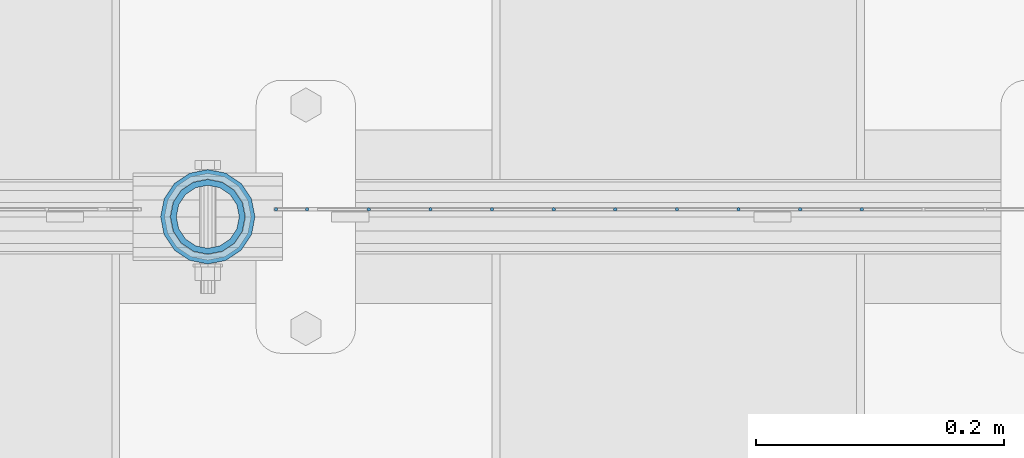
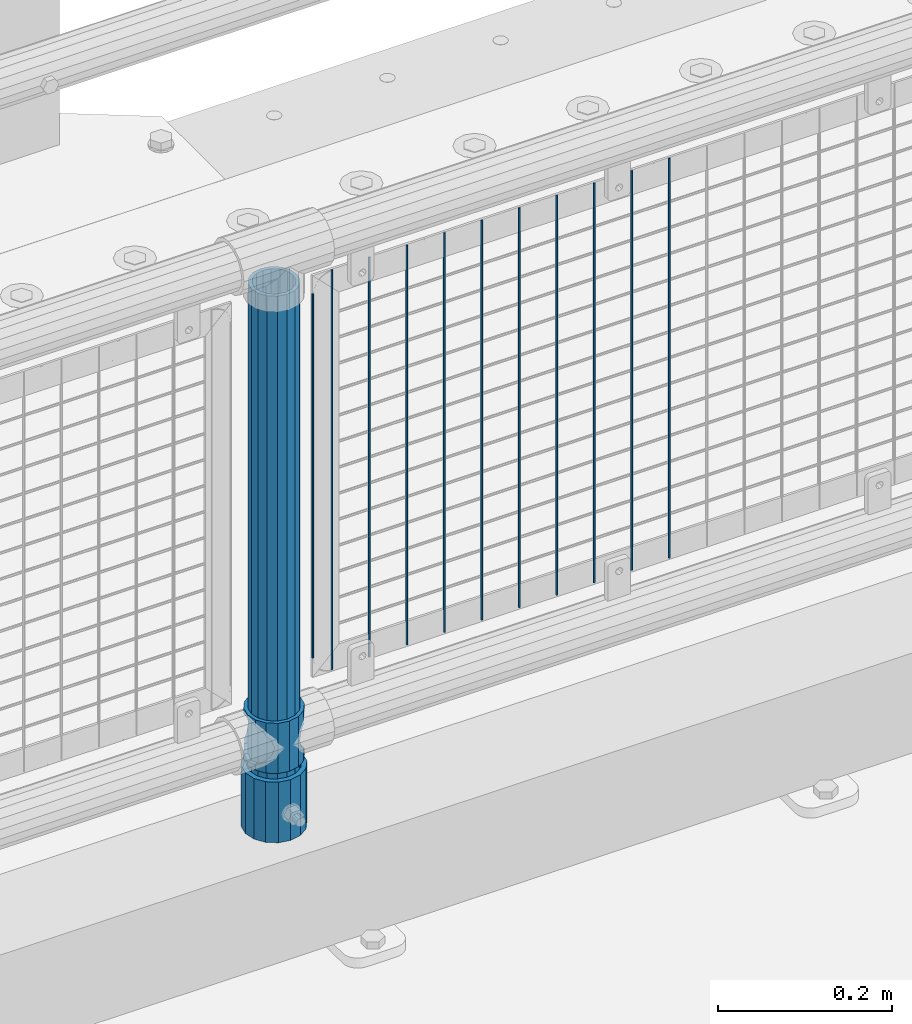
# One storey, part 74 of 257: 14 columns.
"""IFC2X3 building model written with IfcOpenShell, lengths in millimetres."""

import ifcopenshell
import ifcopenshell.guid

model = None  # the IFC model being written
_history = None  # IfcOwnerHistory: only IFC2X3 demands one
_inside = {}  # id of a spatial element -> (the spatial element, [elements in it])
_under = {}  # id of a project, library or spatial element -> (it, [spatial elements below it])
_declared = {}  # id of a project -> (the project, [libraries it declares])
_typed = {}  # id of a type object -> (the type object, [elements of that type])
_made_of = {}  # id of a material, layer set ... -> (it, [elements and type objects made of it])


def new_model(schema):
    """Start an empty IFC model of exactly this schema.

    Asked for "IFC4X3", IfcOpenShell would pick the latest addendum, in which some entities
    have other attributes; the version numbers below select the first issue.
    IFC2X3 requires an IfcOwnerHistory on every rooted entity: one is made here for all.
    """
    global model, _history
    if schema == "IFC4X3":
        model = ifcopenshell.file(schema_version=(4, 3, 0, 0))
    else:
        model = ifcopenshell.file(schema=schema)
    _inside.clear()
    _under.clear()
    _declared.clear()
    _typed.clear()
    _made_of.clear()
    _history = None
    if model.schema == "IFC2X3":
        org = make("IfcOrganization", Name="unknown")
        user = make(
            "IfcPersonAndOrganization",
            ThePerson=make("IfcPerson", FamilyName="unknown"),
            TheOrganization=org,
        )
        app = make(
            "IfcApplication",
            ApplicationDeveloper=org,
            Version="unknown",
            ApplicationFullName="unknown",
            ApplicationIdentifier="unknown",
        )
        _history = make(
            "IfcOwnerHistory",
            OwningUser=user,
            OwningApplication=app,
            ChangeAction="ADDED",
            CreationDate=0,
        )
    return model


def make(cls, **values):
    """One entity of the class cls with the attributes given. An attribute that is None is left unset."""
    return model.create_entity(
        cls, **{name: value for name, value in values.items() if value is not None}
    )


def rooted(cls, **values):
    """An entity with a GlobalId (a new one), such as an element, a storey or a relation."""
    return make(cls, GlobalId=ifcopenshell.guid.new(), OwnerHistory=_history, **values)


def si_unit(unit_type, name, prefix=None):
    """IfcSIUnit, for example si_unit("LENGTHUNIT", "METRE", prefix="MILLI")."""
    return make("IfcSIUnit", UnitType=unit_type, Prefix=prefix, Name=name)


def assignment(units):
    """IfcUnitAssignment: the units of a project."""
    return None if units is None else make("IfcUnitAssignment", Units=units)


def point(xyz):
    """IfcCartesianPoint."""
    return None if xyz is None else make("IfcCartesianPoint", Coordinates=xyz)


def direction(xyz):
    """IfcDirection."""
    return None if xyz is None else make("IfcDirection", DirectionRatios=xyz)


def frame(location, z_axis=None, x_axis=None):
    """IfcAxis2Placement3D, a coordinate frame: its origin and axes. An axis left out is left unset."""
    return make(
        "IfcAxis2Placement3D",
        Location=point(location),
        Axis=direction(z_axis),
        RefDirection=direction(x_axis),
    )


def origin_with_axes():
    """The frame at (0, 0, 0) with the z axis (0, 0, 1) and the x axis (1, 0, 0) written out."""
    return frame((0.0, 0.0, 0.0), z_axis=(0.0, 0.0, 1.0), x_axis=(1.0, 0.0, 0.0))


def place(relative_to, where):
    """IfcLocalPlacement: puts the frame where relative to a parent placement (None: the world)."""
    return make(
        "IfcLocalPlacement", PlacementRelTo=relative_to, RelativePlacement=where
    )


def context(
    kind, dimensions, precision=None, world=None, true_north=None, identifier=None
):
    """IfcGeometricRepresentationContext, for example the 3D "Model" context."""
    return make(
        "IfcGeometricRepresentationContext",
        ContextIdentifier=identifier,
        ContextType=kind,
        CoordinateSpaceDimension=dimensions,
        Precision=precision,
        WorldCoordinateSystem=world,
        TrueNorth=true_north,
    )


def subcontext(parent, identifier, kind, view, scale=None):
    """IfcGeometricRepresentationSubContext, for example "Body" below "Model"."""
    return make(
        "IfcGeometricRepresentationSubContext",
        ContextIdentifier=identifier,
        ContextType=kind,
        ParentContext=parent,
        TargetScale=scale,
        TargetView=view,
    )


def project(units=None, contexts=None):
    """IfcProject with its units and contexts."""
    return rooted(
        "IfcProject",
        Name="project",
        RepresentationContexts=contexts,
        UnitsInContext=assignment(units),
    )


def spatial(cls, under=None, at=None, **own):
    """A site, building, storey or space (cls), placed at a placement, below another one or the project."""
    s = rooted(cls, ObjectPlacement=at, **own)
    if under is not None:
        _under.setdefault(under.id(), (under, []))[1].append(s)
    return s


def faces_of(points, faces, orient=None, outer=None):
    """IfcFace entities. A face is a list of loops; a loop is a list of indices into points, from 0.

    orient and outer hold one flag for each loop. By default every Orientation is true, the
    first loop of a face is its IfcFaceOuterBound and the others are IfcFaceBound.
    """
    made = []
    for i, loops in enumerate(faces):
        bounds = []
        for j, loop in enumerate(loops):
            is_outer = j == 0 if outer is None else outer[i][j]
            bounds.append(
                make(
                    "IfcFaceOuterBound" if is_outer else "IfcFaceBound",
                    Bound=make("IfcPolyLoop", Polygon=[points[k] for k in loop]),
                    Orientation=True if orient is None else orient[i][j],
                )
            )
        made.append(make("IfcFace", Bounds=bounds))
    return made


def faceted_brep(points, faces, orient=None, outer=None, voids=None):
    """IfcFacetedBrep: a solid bounded by flat faces; with voids (closed shells), ...WithVoids."""
    shared = [point(p) for p in points]
    hull = make("IfcClosedShell", CfsFaces=faces_of(shared, faces, orient, outer))
    if voids is None:
        return make("IfcFacetedBrep", Outer=hull)
    return make(
        "IfcFacetedBrepWithVoids",
        Outer=hull,
        Voids=[
            make(cls, CfsFaces=faces_of(shared, fs, o, b)) for cls, fs, o, b in voids
        ],
    )


def shape(context_of_items, identifier, shape_type, items):
    """IfcShapeRepresentation: the items that make up one representation, for example the "Body"."""
    return make(
        "IfcShapeRepresentation",
        ContextOfItems=context_of_items,
        RepresentationIdentifier=identifier,
        RepresentationType=shape_type,
        Items=items,
    )


def material(Name=None, Category=None):
    """IfcMaterial."""
    return make("IfcMaterial", Name=Name, Category=Category)


def made_of(thing, what):
    """Note that an element or type object is made of a material, layer set ...; save() writes the relation."""
    if what is not None:
        _made_of.setdefault(what.id(), (what, []))[1].append(thing)
    return thing


def type_object(cls, material=None, **own):
    """A type object (cls), such as IfcWallType, which elements share."""
    return made_of(rooted(cls, **own), material)


def element(
    cls,
    number,
    at=None,
    inside=None,
    cuts=None,
    type_object=None,
    material=None,
    context=None,
    identifier="Body",
    shape_type=None,
    held_by="IfcProductDefinitionShape",
    body=None,
    shapes=None,
    **own,
):
    """One element of the class cls, such as IfcWall. Its Tag is "e" and its number.

    at: its placement. inside: the storey or other place that contains it. cuts: it is an
    opening in that element (IfcRelVoidsElement). A single representation is given by context,
    identifier, shape_type and body (its items); several are given by shapes. held_by: the class
    of the entity that holds the representations. save() writes the other relations.
    """
    e = rooted(cls, Tag="e%d" % number, ObjectPlacement=at, **own)
    if body is not None:
        shapes = [shape(context, identifier, shape_type, body)]
    if shapes is not None:
        e.Representation = make(held_by, Representations=shapes)
    if inside is not None:
        _inside.setdefault(inside.id(), (inside, []))[1].append(e)
    if cuts is not None:
        rooted(
            "IfcRelVoidsElement", RelatingBuildingElement=cuts, RelatedOpeningElement=e
        )
    if type_object is not None:
        _typed.setdefault(type_object.id(), (type_object, []))[1].append(e)
    return made_of(e, material)


def aggregate(whole, parts):
    """IfcRelAggregates: a whole, such as a stair, and the parts it consists of."""
    return rooted("IfcRelAggregates", RelatingObject=whole, RelatedObjects=parts)


def save(model, path):
    """Write the relations noted so far, then the file.

    IfcRelAggregates (storeys below a building ...), IfcRelContainedInSpatialStructure (elements
    in a storey), IfcRelDefinesByType, IfcRelAssociatesMaterial and IfcRelDeclares: one each for
    every whole, place, type object, material and project.
    """
    for whole, parts in _under.values():
        aggregate(whole, parts)
    for where, things in _inside.values():
        rooted(
            "IfcRelContainedInSpatialStructure",
            RelatedElements=things,
            RelatingStructure=where,
        )
    for kind, things in _typed.values():
        rooted("IfcRelDefinesByType", RelatedObjects=things, RelatingType=kind)
    for what, things in _made_of.values():
        rooted("IfcRelAssociatesMaterial", RelatedObjects=things, RelatingMaterial=what)
    for by, libraries in _declared.values():
        rooted("IfcRelDeclares", RelatingContext=by, RelatedDefinitions=libraries)
    model.write(path)


model = new_model("IFC2X3")

# Units and contexts
model_context = context("Model", 3, precision=1e-05, world=origin_with_axes())
body_context = subcontext(model_context, "Body", "Model", "MODEL_VIEW")
ifc_project = project(units=[si_unit("LENGTHUNIT", "METRE", prefix="MILLI"), si_unit("AREAUNIT", "SQUARE_METRE"), si_unit("VOLUMEUNIT", "CUBIC_METRE"), si_unit("MASSUNIT", "GRAM", prefix="KILO"), si_unit("TIMEUNIT", "SECOND"), si_unit("PLANEANGLEUNIT", "RADIAN"), si_unit("SOLIDANGLEUNIT", "STERADIAN"), si_unit("THERMODYNAMICTEMPERATUREUNIT", "DEGREE_CELSIUS"), si_unit("LUMINOUSINTENSITYUNIT", "LUMEN")], contexts=[model_context])

# Site, building, storey
site_placement = place(None, origin_with_axes())
site = spatial("IfcSite", under=ifc_project, at=site_placement, CompositionType="ELEMENT")
building_placement = place(site_placement, origin_with_axes())
building = spatial("IfcBuilding", under=site, at=building_placement, Name="Standard", CompositionType="ELEMENT")
storey_placement = place(building_placement, origin_with_axes())
storey = spatial("IfcBuildingStorey", under=building, at=storey_placement, Name="Undefined", CompositionType="ELEMENT", Elevation=0.0)

# Columns
ifc_material_1 = material()
column_type_1 = type_object("IfcColumnType", PredefinedType="NOTDEFINED")
column_1_placement = place(storey_placement, frame((47871.0, 10664.5, 168.02), z_axis=(0.0, 1.0, 0.0), x_axis=(0.0, 0.0, 1.0)))
element("IfcColumn", 1, at=column_1_placement, inside=storey, type_object=column_type_1, material=ifc_material_1, context=body_context, shape_type="Brep", body=[
    faceted_brep([(0.0, -31.75, 0.0), (0.0, -29.3331751572332, 12.1501989775916), (85.0, -29.3331751572332, 12.1501989775916), (85.0, -31.75, 0.0), (0.0, -22.4506403026753, 22.4506403026735), (85.0, -22.4506403026753, 22.4506403026735), (0.0, -12.1501989775934, 29.3331751572332), (85.0, -12.1501989775934, 29.3331751572332), (0.0, 0.0, 31.75), (85.0, 0.0, 31.75), (0.0, 12.1501989775934, 29.3331751572332), (85.0, 12.1501989775934, 29.3331751572332), (0.0, 22.4506403026753, 22.4506403026735), (85.0, 22.4506403026753, 22.4506403026735), (0.0, 29.3331751572332, 12.1501989775916), (85.0, 29.3331751572332, 12.1501989775916), (0.0, 31.75, 0.0), (85.0, 31.75, 0.0), (0.0, 29.3331751572332, -12.1501989775916), (85.0, 29.3331751572332, -12.1501989775916), (0.0, 22.4506403026753, -22.4506403026735), (85.0, 22.4506403026753, -22.4506403026735), (0.0, 12.1501989775934, -29.3331751572332), (85.0, 12.1501989775934, -29.3331751572332), (0.0, 0.0, -31.75), (85.0, 0.0, -31.75), (0.0, -12.1501989775934, -29.3331751572332), (85.0, -12.1501989775934, -29.3331751572332), (0.0, -22.4506403026753, -22.4506403026735), (85.0, -22.4506403026753, -22.4506403026735), (0.0, -29.3331751572332, -12.1501989775916), (85.0, -29.3331751572332, -12.1501989775916), (0.0, -38.0500000000029, 0.0), (0.0, -35.1536162120537, -14.561104601491), (85.0, -35.1536162120537, -14.561104601491), (85.0, -38.0500000000029, 0.0), (0.0, -26.9054130241493, -26.9054130241475), (85.0, -26.9054130241493, -26.9054130241475), (0.0, -14.5611046014892, -35.1536162120537), (85.0, -14.5611046014892, -35.1536162120537), (0.0, 0.0, -38.0499999999993), (85.0, 0.0, -38.0499999999993), (0.0, 14.5611046014892, -35.1536162120537), (85.0, 14.5611046014892, -35.1536162120537), (0.0, 26.9054130241493, -26.9054130241475), (85.0, 26.9054130241493, -26.9054130241475), (0.0, 35.1536162120537, -14.561104601491), (85.0, 35.1536162120537, -14.561104601491), (0.0, 38.0500000000029, 0.0), (85.0, 38.0500000000029, 0.0), (0.0, 35.1536162120537, 14.561104601491), (85.0, 35.1536162120537, 14.561104601491), (0.0, 26.9054130241493, 26.9054130241475), (85.0, 26.9054130241493, 26.9054130241475), (0.0, 14.5611046014892, 35.1536162120537), (85.0, 14.5611046014892, 35.1536162120537), (0.0, 0.0, 38.0499999999993), (85.0, 0.0, 38.0499999999993), (0.0, -14.5611046014892, 35.1536162120537), (85.0, -14.5611046014892, 35.1536162120537), (0.0, -26.9054130241493, 26.9054130241475), (85.0, -26.9054130241493, 26.9054130241475), (0.0, -35.1536162120537, 14.561104601491), (85.0, -35.1536162120537, 14.561104601491)], [[[0, 1, 2, 3]], [[1, 4, 5, 2]], [[4, 6, 7, 5]], [[6, 8, 9, 7]], [[8, 10, 11, 9]], [[10, 12, 13, 11]], [[12, 14, 15, 13]], [[14, 16, 17, 15]], [[16, 18, 19, 17]], [[18, 20, 21, 19]], [[20, 22, 23, 21]], [[22, 24, 25, 23]], [[24, 26, 27, 25]], [[26, 28, 29, 27]], [[28, 30, 31, 29]], [[30, 0, 3, 31]], [[32, 33, 34, 35]], [[33, 36, 37, 34]], [[36, 38, 39, 37]], [[38, 40, 41, 39]], [[40, 42, 43, 41]], [[42, 44, 45, 43]], [[44, 46, 47, 45]], [[46, 48, 49, 47]], [[48, 50, 51, 49]], [[50, 52, 53, 51]], [[52, 54, 55, 53]], [[54, 56, 57, 55]], [[56, 58, 59, 57]], [[58, 60, 61, 59]], [[60, 62, 63, 61]], [[62, 32, 35, 63]], [[37, 39, 41, 43, 45, 47, 49, 51, 53, 55, 57, 59, 61, 63, 35, 34], [5, 7, 9, 11, 13, 15, 17, 19, 21, 23, 25, 27, 29, 31, 3, 2]], [[62, 60, 58, 56, 54, 52, 50, 48, 46, 44, 42, 40, 38, 36, 33, 32], [30, 28, 26, 24, 22, 20, 18, 16, 14, 12, 10, 8, 6, 4, 1, 0]]]),
])
ifc_material_2 = material(Name="Misc_Undefined")
column_type_2 = type_object("IfcColumnType", PredefinedType="NOTDEFINED")
column_2_placement = place(storey_placement, frame((47871.0, 10664.5, 263.02), z_axis=(-1.0, 0.0, 0.0), x_axis=(0.0, 0.0, 1.0)))
element("IfcColumn", 2, at=column_2_placement, inside=storey, type_object=column_type_2, material=ifc_material_2, context=body_context, shape_type="Brep", body=[
    faceted_brep([(63.1897438117172, 11.6144421722802, -32.8397438117245), (63.1897438117172, 11.6144421722802, -28.0397438117143), (56.6106908090114, 21.4606908090118, -21.4606908090136), (56.6106908090114, 21.4606908090118, -27.1226768591077), (61.9623795176756, 13.4513226476338, -32.4743655677739), (46.7644421722801, 28.0397438117179, -11.6144421722784), (46.7644421722801, 28.0397438117179, -20.0882031229921), (51.5310424080039, 24.8548033587067, -24.8548033587067), (35.1500000000015, 30.35, 0.0), (35.1499999999996, 30.3500000000004, -16.6306603983758), (23.5355578277192, 28.0397438117179, -11.6144421722784), (23.5355578277192, 28.0397438117179, -20.0882031229921), (18.7689575919954, 24.8548033587067, -24.8548033587067), (13.6893091909879, 21.4606908090118, -21.4606908090136), (13.6893091909879, 21.4606908090118, -27.1226768591077), (8.3376204823237, 13.4513226476338, -32.4743655677739), (7.11025618828211, 11.6144421722802, -28.0397438117143), (7.11025618828211, 11.6144421722802, -32.8397438117245), (4.79999999999961, 0.0, -30.3499999999985), (4.79999999999961, 0.0, -35.1500000000015), (7.11025618828205, -11.6144421722802, -28.0397438117143), (7.11025618828205, -11.6144421722802, -32.8397438117245), (13.6893091909879, -21.4606908090118, -21.4606908090136), (13.6893091909879, -21.4606908090118, -27.1226768591077), (8.33762048232484, -13.4513226476338, -32.4743655677739), (23.5355578277191, -28.0397438117179, -11.6144421722784), (23.5355578277191, -28.0397438117179, -20.0882031229849), (18.7689575919987, -24.8548033587067, -24.8548033587067), (35.1500000000015, -30.35, 0.0), (35.1499999999996, -30.3500000000004, -16.6306603983685), (46.7644421722801, -28.0397438117179, -11.6144421722784), (46.7644421722801, -28.0397438117179, -20.0882031229849), (51.5310424080038, -24.8548033587067, -24.8548033587067), (56.6106908090114, -21.4606908090118, -21.4606908090136), (56.6106908090114, -21.4606908090118, -27.1226768591077), (61.9623795176756, -13.4513226476338, -32.4743655677739), (63.1897438117172, -11.6144421722802, -28.0397438117143), (63.1897438117172, -11.6144421722802, -32.8397438117245), (65.4999999999997, 0.0, -30.3499999999985), (65.4999999999997, 0.0, -35.1500000000015), (0.0, -28.0397438117179, -11.6144421722784), (0.0, -30.3500000000004, 0.0), (0.0, -21.4606908090118, -21.4606908090136), (0.0, -11.6144421722802, -28.0397438117143), (0.0, 0.0, -30.3499999999985), (0.0, 11.6144421722802, -28.0397438117143), (0.0, 21.4606908090118, -21.4606908090136), (0.0, 28.0397438117179, -11.6144421722784), (0.0, 30.3500000000004, 0.0), (0.0, 28.0397438117179, 11.6144421722784), (23.5355578277192, 28.0397438117179, 11.6144421722784), (0.0, 21.4606908090118, 21.4606908090136), (13.6893091909879, 21.4606908090118, 21.4606908090136), (0.0, 11.6144421722802, 28.0397438117143), (7.11025618828211, 11.6144421722802, 28.0397438117143), (0.0, 0.0, 30.3499999999985), (4.79999999999961, 0.0, 30.3499999999985), (0.0, -11.6144421722802, 28.0397438117143), (7.11025618828205, -11.6144421722802, 28.0397438117143), (0.0, -21.4606908090118, 21.4606908090136), (13.6893091909879, -21.4606908090118, 21.4606908090136), (0.0, -28.0397438117179, 11.6144421722784), (23.5355578277191, -28.0397438117179, 11.6144421722784), (0.0, -32.4743655677721, 13.4513226476338), (0.0, -35.1499999999996, 0.0), (70.2999999999993, -35.1499999999996, 0.0), (70.2999999999993, -32.4743655677721, 13.4513226476338), (0.0, 13.4513226476338, -32.4743655677739), (0.0, 24.8548033587067, -24.8548033587067), (0.0, 0.0, -35.1499999999996), (0.0, -13.4513226476338, -32.4743655677739), (0.0, -24.8548033587067, -24.8548033587067), (0.0, -24.8548033587067, 24.8548033587067), (0.0, -13.4513226476338, 32.4743655677739), (0.0, 0.0, 35.1499999999996), (0.0, 13.4513226476338, 32.4743655677739), (0.0, 24.8548033587067, 24.8548033587067), (0.0, 32.4743655677721, 13.4513226476338), (0.0, 35.1499999999996, 0.0), (0.0, 32.4743655677721, -13.4513226476338), (0.0, -32.4743655677721, -13.4513226476338), (70.2999999999993, 32.4743655677721, 13.4513226476338), (70.2999999999993, 35.1499999999996, 0.0), (70.2999999999993, 32.4743655677721, -13.4513226476338), (70.2999999999993, 24.8548033587067, -24.8548033587067), (70.2999999999993, 13.4513226476338, -32.4743655677739), (70.2999999999993, 0.0, -35.1500000000015), (70.2999999999993, -13.4513226476338, -32.4743655677739), (70.2999999999993, -24.8548033587067, -24.8548033587067), (70.2999999999993, -32.4743655677721, -13.4513226476338), (70.2999999999993, 28.0397438117179, 11.6144421722784), (70.2999999999993, 21.4606908090118, 21.4606908090136), (56.6106908090114, 21.4606908090118, 21.4606908090136), (46.7644421722801, 28.0397438117179, 11.6144421722784), (70.2999999999993, 11.6144421722802, 28.0397438117143), (63.1897438117172, 11.6144421722802, 28.0397438117143), (70.2999999999993, 0.0, 30.3499999999985), (65.4999999999997, 0.0, 30.3499999999985), (70.2999999999993, -11.6144421722802, 28.0397438117143), (63.1897438117172, -11.6144421722802, 28.0397438117143), (70.2999999999993, -21.4606908090118, 21.4606908090136), (56.6106908090114, -21.4606908090118, 21.4606908090136), (70.2999999999993, -28.0397438117179, 11.6144421722784), (46.7644421722801, -28.0397438117179, 11.6144421722784), (70.2999999999993, -11.6144421722802, -28.0397438117143), (70.2999999999993, 0.0, -30.3499999999985), (70.2999999999993, -21.4606908090118, -21.4606908090136), (70.2999999999993, -28.0397438117179, -11.6144421722784), (70.2999999999993, -30.3500000000004, 0.0), (70.2999999999993, 24.8548033587067, 24.8548033587067), (70.2999999999993, 13.4513226476338, 32.4743655677739), (70.2999999999993, 0.0, 35.1500000000015), (70.2999999999993, -13.4513226476338, 32.4743655677739), (70.2999999999993, -24.8548033587067, 24.8548033587067), (70.2999999999993, 30.3500000000004, 0.0), (70.2999999999993, 28.0397438117179, -11.6144421722784), (70.2999999999993, 21.4606908090118, -21.4606908090136), (70.2999999999993, 11.6144421722802, -28.0397438117143), (61.9623795176756, 13.4513226476338, 32.4743655677739), (51.5310424080039, 24.8548033587067, 24.8548033587067), (56.6106908090114, 21.4606908090118, 27.1226768591077), (65.4999999999997, 0.0, 35.1500000000015), (63.1897438117172, 11.6144421722802, 32.8397438117172), (63.1897438117172, -11.6144421722802, 32.8397438117172), (61.9623795176756, -13.4513226476338, 32.4743655677739), (56.6106908090114, -21.4606908090118, 27.1226768591077), (51.5310424080071, -24.8548033587067, 24.8548033587067), (18.7689575919987, -24.8548033587067, 24.8548033587067), (46.7644421722801, -28.0397438117179, 20.0882031229703), (35.1499999999996, -30.3500000000004, 16.6306603983539), (23.5355578277191, -28.0397438117179, 20.0882031229703), (8.3376204823237, -13.4513226476338, 32.4743655677739), (13.6893091909879, -21.4606908090118, 27.1226768591077), (4.79999999999961, 0.0, 35.1500000000015), (7.11025618828205, -11.6144421722802, 32.8397438117172), (7.11025618828211, 11.6144421722802, 32.8397438117172), (8.3376204823237, 13.4513226476338, 32.4743655677739), (13.6893091909879, 21.4606908090118, 27.1226768591077), (18.7689575919954, 24.8548033587067, 24.8548033587067), (23.5355578277192, 28.0397438117179, 20.0882031229849), (35.1499999999996, 30.3500000000004, 16.6306603983685), (46.7644421722801, 28.0397438117179, 20.0882031229849)], [[[0, 1, 2, 3, 4]], [[3, 2, 5, 6, 7]], [[6, 5, 8, 9]], [[9, 8, 10, 11]], [[12, 11, 10, 13, 14]], [[15, 14, 13, 16, 17]], [[17, 16, 18, 19]], [[19, 18, 20, 21]], [[21, 20, 22, 23, 24]], [[23, 22, 25, 26, 27]], [[26, 25, 28, 29]], [[29, 28, 30, 31]], [[32, 31, 30, 33, 34]], [[35, 34, 33, 36, 37]], [[37, 36, 38, 39]], [[39, 38, 1, 0]], [[40, 41, 28, 25]], [[42, 40, 25, 22]], [[43, 42, 22, 20]], [[44, 43, 20, 18]], [[45, 44, 18, 16]], [[46, 45, 16, 13]], [[47, 46, 13, 10]], [[48, 47, 10, 8]], [[49, 48, 8, 50]], [[51, 49, 50, 52]], [[53, 51, 52, 54]], [[55, 53, 54, 56]], [[57, 55, 56, 58]], [[59, 57, 58, 60]], [[61, 59, 60, 62]], [[41, 61, 62, 28]], [[63, 64, 65, 66]], [[67, 68, 12, 14, 15]], [[69, 67, 15, 17, 19]], [[24, 70, 69, 19, 21]], [[27, 71, 70, 24, 23]], [[63, 72, 73, 74, 75, 76, 77, 78, 79, 68, 67, 69, 70, 71, 80, 64], [40, 42, 43, 44, 45, 46, 47, 48, 49, 51, 53, 55, 57, 59, 61, 41]], [[78, 77, 81, 82]], [[79, 78, 82, 83]], [[9, 11, 12, 68, 79, 83, 84, 7, 6]], [[7, 84, 85, 4, 3]], [[4, 85, 86, 39, 0]], [[87, 88, 32, 34, 35]], [[86, 87, 35, 37, 39]], [[88, 89, 80, 71, 27, 26, 29, 31, 32]], [[64, 80, 89, 65]], [[90, 91, 92, 93]], [[91, 94, 95, 92]], [[94, 96, 97, 95]], [[96, 98, 99, 97]], [[98, 100, 101, 99]], [[100, 102, 103, 101]], [[104, 105, 38, 36]], [[106, 104, 36, 33]], [[107, 106, 33, 30]], [[108, 107, 30, 28]], [[102, 108, 28, 103]], [[88, 87, 86, 85, 84, 83, 82, 81, 109, 110, 111, 112, 113, 66, 65, 89], [100, 98, 96, 94, 91, 90, 114, 115, 116, 117, 105, 104, 106, 107, 108, 102]], [[118, 110, 109, 119, 120]], [[121, 111, 110, 118, 122]], [[112, 111, 121, 123, 124]], [[113, 112, 124, 125, 126]], [[127, 72, 63, 66, 113, 126, 128, 129, 130]], [[131, 73, 72, 127, 132]], [[133, 74, 73, 131, 134]], [[75, 74, 133, 135, 136]], [[76, 75, 136, 137, 138]], [[119, 109, 81, 77, 76, 138, 139, 140, 141]], [[92, 120, 119, 141, 93]], [[95, 122, 118, 120, 92]], [[97, 121, 122, 95]], [[99, 123, 121, 97]], [[101, 125, 124, 123, 99]], [[103, 128, 126, 125, 101]], [[28, 129, 128, 103]], [[62, 130, 129, 28]], [[60, 132, 127, 130, 62]], [[58, 134, 131, 132, 60]], [[56, 133, 134, 58]], [[54, 135, 133, 56]], [[52, 137, 136, 135, 54]], [[50, 139, 138, 137, 52]], [[8, 140, 139, 50]], [[93, 141, 140, 8]], [[114, 90, 93, 8]], [[115, 114, 8, 5]], [[116, 115, 5, 2]], [[117, 116, 2, 1]], [[105, 117, 1, 38]]]),
])
column_type_3 = type_object("IfcColumnType", PredefinedType="NOTDEFINED")
column_3_placement = place(storey_placement, frame((47871.0, 10664.5, 168.02), z_axis=(-1.0, 0.0, 0.0), x_axis=(0.0, 0.0, 1.0)))
element("IfcColumn", 3, at=column_3_placement, inside=storey, type_object=column_type_3, material=ifc_material_1, context=body_context, shape_type="Brep", body=[
    faceted_brep([(0.0, -25.3500000000004, 0.0), (0.0, -23.4203461491616, 9.70102501045767), (760.0, -23.4203461491616, 9.70102501045767), (760.0, -25.3500000000004, 0.0), (0.0, -17.9251569030785, 17.9251569030821), (760.0, -17.9251569030785, 17.9251569030821), (0.0, -9.70102501045585, 23.4203461491634), (760.0, -9.70102501045585, 23.4203461491634), (0.0, 0.0, 25.3499999999985), (760.0, 0.0, 25.3499999999985), (0.0, 9.70102501045585, 23.4203461491634), (760.0, 9.70102501045585, 23.4203461491634), (0.0, 17.9251569030785, 17.9251569030821), (760.0, 17.9251569030785, 17.9251569030821), (0.0, 23.4203461491616, 9.70102501045767), (760.0, 23.4203461491616, 9.70102501045767), (0.0, 25.3500000000004, 0.0), (760.0, 25.3500000000004, 0.0), (0.0, 23.4203461491616, -9.70102501045767), (760.0, 23.4203461491616, -9.70102501045767), (0.0, 17.9251569030785, -17.9251569030821), (760.0, 17.9251569030785, -17.9251569030821), (0.0, 9.70102501045585, -23.4203461491634), (760.0, 9.70102501045585, -23.4203461491634), (0.0, 0.0, -25.3499999999985), (760.0, 0.0, -25.3499999999985), (0.0, -9.70102501045585, -23.4203461491634), (760.0, -9.70102501045585, -23.4203461491634), (0.0, -17.9251569030785, -17.9251569030821), (760.0, -17.9251569030785, -17.9251569030821), (0.0, -23.4203461491616, -9.70102501045767), (760.0, -23.4203461491616, -9.70102501045767), (0.0, -30.1499999999996, 0.0), (0.0, -27.8549679052157, -11.5379054858058), (760.0, -27.8549679052157, -11.5379054858058), (760.0, -30.1499999999996, 0.0), (0.0, -21.3192694527752, -21.3192694527752), (760.0, -21.3192694527752, -21.3192694527752), (0.0, -11.5379054858076, -27.8549679052157), (760.0, -11.5379054858076, -27.8549679052157), (0.0, 0.0, -30.1500000000015), (760.0, 0.0, -30.1500000000015), (0.0, 11.5379054858076, -27.8549679052157), (760.0, 11.5379054858076, -27.8549679052157), (0.0, 21.3192694527752, -21.3192694527752), (760.0, 21.3192694527752, -21.3192694527752), (0.0, 27.8549679052157, -11.5379054858058), (760.0, 27.8549679052157, -11.5379054858058), (0.0, 30.1499999999996, 0.0), (760.0, 30.1499999999996, 0.0), (0.0, 27.8549679052157, 11.5379054858058), (760.0, 27.8549679052157, 11.5379054858058), (0.0, 21.3192694527752, 21.3192694527752), (760.0, 21.3192694527752, 21.3192694527752), (0.0, 11.5379054858076, 27.8549679052157), (760.0, 11.5379054858076, 27.8549679052157), (0.0, 0.0, 30.1500000000015), (760.0, 0.0, 30.1500000000015), (0.0, -11.5379054858076, 27.8549679052157), (760.0, -11.5379054858076, 27.8549679052157), (0.0, -21.3192694527752, 21.3192694527752), (760.0, -21.3192694527752, 21.3192694527752), (0.0, -27.8549679052157, 11.5379054858058), (760.0, -27.8549679052157, 11.5379054858058)], [[[0, 1, 2, 3]], [[1, 4, 5, 2]], [[4, 6, 7, 5]], [[6, 8, 9, 7]], [[8, 10, 11, 9]], [[10, 12, 13, 11]], [[12, 14, 15, 13]], [[14, 16, 17, 15]], [[16, 18, 19, 17]], [[18, 20, 21, 19]], [[20, 22, 23, 21]], [[22, 24, 25, 23]], [[24, 26, 27, 25]], [[26, 28, 29, 27]], [[28, 30, 31, 29]], [[30, 0, 3, 31]], [[32, 33, 34, 35]], [[33, 36, 37, 34]], [[36, 38, 39, 37]], [[38, 40, 41, 39]], [[40, 42, 43, 41]], [[42, 44, 45, 43]], [[44, 46, 47, 45]], [[46, 48, 49, 47]], [[48, 50, 51, 49]], [[50, 52, 53, 51]], [[52, 54, 55, 53]], [[54, 56, 57, 55]], [[56, 58, 59, 57]], [[58, 60, 61, 59]], [[60, 62, 63, 61]], [[62, 32, 35, 63]], [[37, 39, 41, 43, 45, 47, 49, 51, 53, 55, 57, 59, 61, 63, 35, 34], [5, 7, 9, 11, 13, 15, 17, 19, 21, 23, 25, 27, 29, 31, 3, 2]], [[62, 60, 58, 56, 54, 52, 50, 48, 46, 44, 42, 40, 38, 36, 33, 32], [30, 28, 26, 24, 22, 20, 18, 16, 14, 12, 10, 8, 6, 4, 1, 0]]]),
])
column_type_4 = type_object("IfcColumnType", Name="D3", PredefinedType="NOTDEFINED")
for number, where, z_axis, x_axis in (
    (4, (48397.895, 10670.5, 353.020000000001), (-1.0, 0.0, 0.0), (0.0, 0.0, 1.0)),
    (5, (48348.24, 10670.5, 353.020000000001), (-1.0, 0.0, 0.0), (0.0, 0.0, 1.0)),
    (6, (48298.585, 10670.5, 353.020000000001), (-1.0, 0.0, 0.0), (0.0, 0.0, 1.0)),
    (7, (48248.93, 10670.5, 353.020000000001), (-1.0, 0.0, 0.0), (0.0, 0.0, 1.0)),
    (8, (48199.275, 10670.5, 353.020000000001), (-1.0, 0.0, 0.0), (0.0, 0.0, 1.0)),
    (9, (48149.62, 10670.5, 353.020000000001), (-1.0, 0.0, 0.0), (0.0, 0.0, 1.0)),
    (10, (48099.965, 10670.5, 353.020000000001), (-1.0, 0.0, 0.0), (0.0, 0.0, 1.0)),
    (11, (48050.3103448276, 10670.5, 353.020000000001), (-1.0, 0.0, 0.0), (0.0, 0.0, 1.0)),
    (12, (48000.6551724138, 10670.5, 353.020000000001), (-0.999999999962839, 0.0, 8.62099999968473e-06), (8.62099999949798e-06, 0.0, 0.999999999962839)),
):
    element("IfcColumn", number, at=place(storey_placement, frame(where, z_axis=z_axis, x_axis=x_axis)), inside=storey, type_object=column_type_4, material=ifc_material_2, ObjectType="D3", context=body_context, shape_type="Brep", body=[
        faceted_brep([(0.0, -1.5, -5.6843418860808e-14), (0.0, -0.750000000001819, -1.29903810567669), (560.0, -0.75, -1.29903810567339), (560.0, -1.5, 0.0), (7.27595761418343e-12, 0.749999999998181, -1.29903810567669), (560.0, 0.75, -1.29903810567339), (0.0, 1.5, -5.6843418860808e-14), (560.0, 1.5, 0.0), (7.27595761418343e-12, 0.749999999998181, 1.29903810567669), (560.0, 0.75, 1.29903810567339), (0.0, -0.750000000001819, 1.29903810567669), (560.0, -0.75, 1.29903810567339)], [[[0, 1, 2, 3]], [[1, 4, 5, 2]], [[4, 6, 7, 5]], [[6, 8, 9, 7]], [[8, 10, 11, 9]], [[10, 0, 3, 11]], [[5, 7, 9, 11, 3, 2]], [[10, 8, 6, 4, 1, 0]]]),
    ])
column_4_placement = place(storey_placement, frame((47926.0, 10670.5, 378.020000000001), z_axis=(-1.0, 0.0, 0.0), x_axis=(0.0, 0.0, 1.0)))
element("IfcColumn", 13, at=column_4_placement, inside=storey, type_object=column_type_4, material=ifc_material_2, ObjectType="D3", context=body_context, shape_type="Brep", body=[
    faceted_brep([(0.0, -1.5, -5.6843418860808e-14), (0.0, -0.750000000001819, -1.29903810567669), (510.0, -0.75, -1.29903810567339), (510.0, -1.5, 0.0), (7.27595761418343e-12, 0.749999999998181, -1.29903810567669), (510.0, 0.75, -1.29903810567339), (0.0, 1.5, -5.6843418860808e-14), (510.0, 1.5, 0.0), (7.27595761418343e-12, 0.749999999998181, 1.29903810567669), (510.0, 0.75, 1.29903810567339), (0.0, -0.750000000001819, 1.29903810567669), (510.0, -0.75, 1.29903810567339)], [[[0, 1, 2, 3]], [[1, 4, 5, 2]], [[4, 6, 7, 5]], [[6, 8, 9, 7]], [[8, 10, 11, 9]], [[10, 0, 3, 11]], [[5, 7, 9, 11, 3, 2]], [[10, 8, 6, 4, 1, 0]]]),
])
column_5_placement = place(storey_placement, frame((47951.0, 10670.5, 353.020000000001), z_axis=(-1.0, 0.0, 0.0), x_axis=(0.0, 0.0, 1.0)))
element("IfcColumn", 14, at=column_5_placement, inside=storey, type_object=column_type_4, material=ifc_material_2, ObjectType="D3", context=body_context, shape_type="Brep", body=[
    faceted_brep([(0.0, -1.5, -5.6843418860808e-14), (0.0, -0.750000000001819, -1.29903810567669), (560.0, -0.75, -1.29903810567339), (560.0, -1.5, 0.0), (7.27595761418343e-12, 0.749999999998181, -1.29903810567669), (560.0, 0.75, -1.29903810567339), (0.0, 1.5, -5.6843418860808e-14), (560.0, 1.5, 0.0), (7.27595761418343e-12, 0.749999999998181, 1.29903810567669), (560.0, 0.75, 1.29903810567339), (0.0, -0.750000000001819, 1.29903810567669), (560.0, -0.75, 1.29903810567339)], [[[0, 1, 2, 3]], [[1, 4, 5, 2]], [[4, 6, 7, 5]], [[6, 8, 9, 7]], [[8, 10, 11, 9]], [[10, 0, 3, 11]], [[5, 7, 9, 11, 3, 2]], [[10, 8, 6, 4, 1, 0]]]),
])

save(model, "model.ifc")
